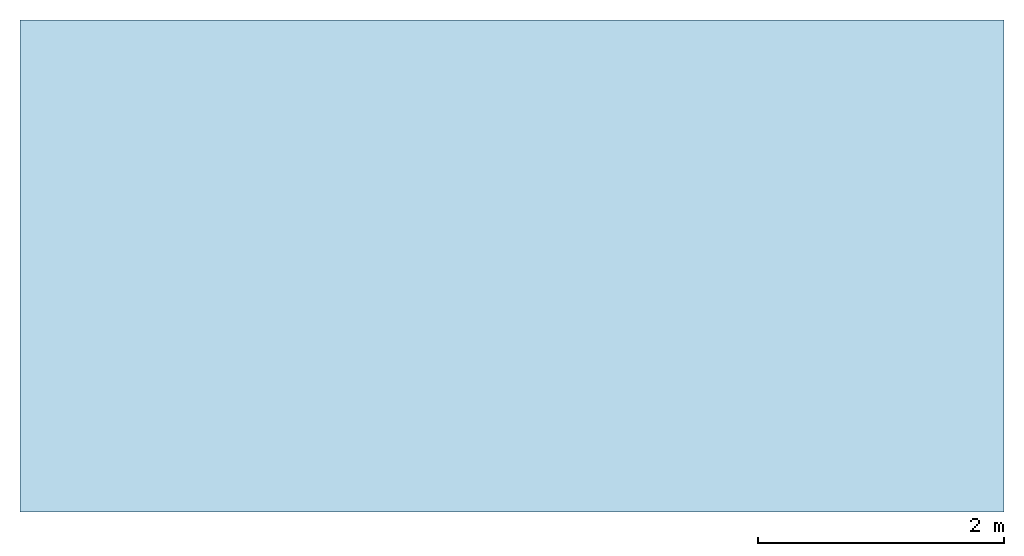
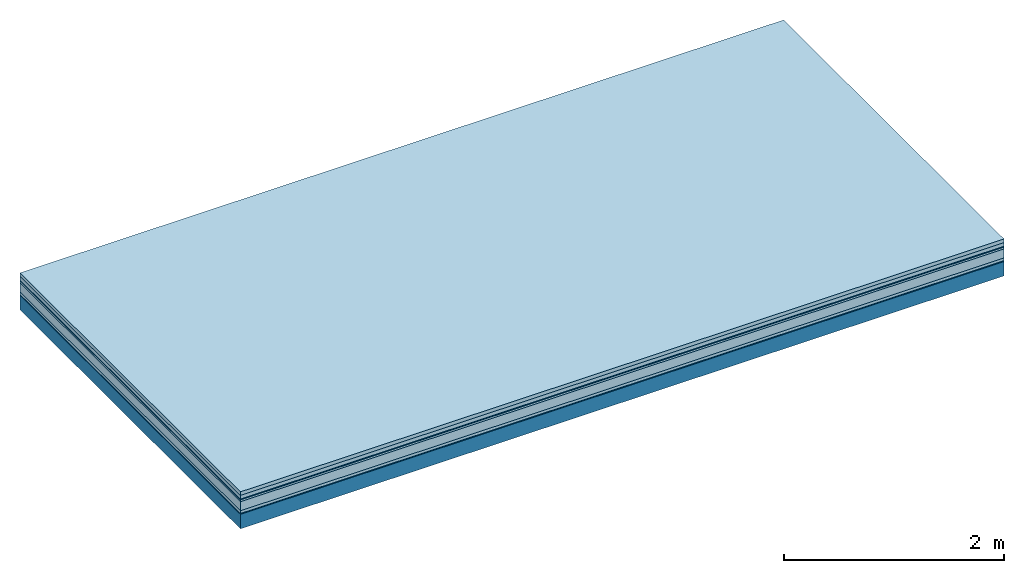
# One storey: 7 plates, 1 member, 1 element without a shape of its own.
"""IFC4 building model written with IfcOpenShell, lengths in metres."""

from ifc_helpers import new_model, si_unit, derived_unit, direction, frame, frame_2d, origin, origin_with_axes, place, context, project, spatial, rectangle, extrude, material, layer, layer_set, type_object, element, aggregate, save


model = new_model("IFC4")

# Units and contexts
plan_context = context("Plan", 3, precision=1e-05, world=origin(), true_north=direction((0.0, 1.0)))
model_context = context("Model", 3, precision=1e-05, world=origin(), true_north=direction((0.0, 1.0)))
ifc_project = project(units=[si_unit("LENGTHUNIT", "METRE"), derived_unit("SOUNDPRESSUREUNIT", [(si_unit("PRESSUREUNIT", "PASCAL", prefix="MICRO"), 0)]), si_unit("ENERGYUNIT", "JOULE", prefix="MEGA"), si_unit("MASSUNIT", "GRAM", prefix="KILO"), derived_unit("THERMALTRANSMITTANCEUNIT", [(si_unit("POWERUNIT", "WATT"), 1), (si_unit("AREAUNIT", "SQUARE_METRE"), -1), (si_unit("THERMODYNAMICTEMPERATUREUNIT", "KELVIN"), -1)]), derived_unit("AREADENSITYUNIT", [(si_unit("MASSUNIT", "GRAM", prefix="KILO"), 1), (si_unit("AREAUNIT", "SQUARE_METRE"), -1)]), derived_unit("USERDEFINED", [(si_unit("ENERGYUNIT", "JOULE", prefix="MEGA"), 1), (si_unit("AREAUNIT", "SQUARE_METRE"), -1)])], contexts=[plan_context, model_context])

# Site, building, storey
site = spatial("IfcSite", under=ifc_project)
building_placement = place(None, origin())
building = spatial("IfcBuilding", under=site, at=building_placement)
storey_placement = place(building_placement, origin())
storey = spatial("IfcBuildingStorey", under=building, at=storey_placement)

# Slab, member, plates
ifc_material_1 = material(Name="Garden plates", Category="02.007")
ifc_layer_1 = layer(ifc_material_1, 0.04, Name="Use and protection layer 3")
ifc_material_2 = material(Name="Gravel 8-16mm", Category="03.011")
ifc_layer_2 = layer(ifc_material_2, 0.04, Name="Use and protection layer 2")
ifc_material_3 = material(Name="Protective layer", Category="09.007")
ifc_layer_3 = layer(ifc_material_3, 0.01, Name="Use and protection layer 1")
ifc_material_4 = material(Name="Bituminous", Category="09.003")
ifc_layer_4 = layer(ifc_material_4, 0.02, Name="Seal")
ifc_material_5 = material(Category="10.006")
ifc_layer_5 = layer(ifc_material_5, 0.1, Name="Exterior insulation layer 2")
ifc_material_6 = material(Name="(034) 25 boards", Category="10.004")
ifc_layer_6 = layer(ifc_material_6, 0.03, Name="Exterior insulation layer 1")
ifc_material_7 = material(Name="Vapor-permeable barrier", Category="09.006")
ifc_layer_7 = layer(ifc_material_7, 0.01, Name="layer / temporary roof")
ifc_material_8 = material(Name="no composite action")
ifc_layer_8 = layer(ifc_material_8, 0.0, Name="Bond")
ifc_layer_9 = layer(None, 0.16, Name="Support")
ifc_layer_set = layer_set([ifc_layer_1, ifc_layer_2, ifc_layer_3, ifc_layer_4, ifc_layer_5, ifc_layer_6, ifc_layer_7, ifc_layer_8, ifc_layer_9])
slab_type = type_object("IfcSlabType", Name="F0059", PredefinedType="NOTDEFINED", material=ifc_layer_set)
slab_placement = place(None, frame((0.0, 0.0, 0.0), z_axis=(0.0, 0.0, -1.0), x_axis=(1.0, 0.0, 0.0)))
slab = element("IfcSlab", 1, at=slab_placement, inside=storey, type_object=slab_type, material=ifc_layer_set, Name="Slab #1")
ifc_material_9 = material(Name="Solid timber panel")
member_placement = place(slab_placement, origin())
member = element("IfcMember", 2, at=member_placement, material=ifc_material_9, Name="Support", context=plan_context, shape_type="SweptSolid", body=[
    extrude(rectangle(XDim=1.0, YDim=0.16, at=frame_2d((0.5, 0.08), x_axis=(1.0, 0.0))), frame((0.0, 4.0, 0.25), z_axis=(0.0, -1.0, 0.0), x_axis=(1.0, 0.0, 0.0)), (0.0, 0.0, 1.0), 4.0),
    extrude(rectangle(XDim=1.0, YDim=0.16, at=frame_2d((0.5, 0.08), x_axis=(1.0, 0.0))), frame((1.0, 4.0, 0.25), z_axis=(0.0, -1.0, 0.0), x_axis=(1.0, 0.0, 0.0)), (0.0, 0.0, 1.0), 4.0),
    extrude(rectangle(XDim=1.0, YDim=0.16, at=frame_2d((0.5, 0.08), x_axis=(1.0, 0.0))), frame((2.0, 4.0, 0.25), z_axis=(0.0, -1.0, 0.0), x_axis=(1.0, 0.0, 0.0)), (0.0, 0.0, 1.0), 4.0),
    extrude(rectangle(XDim=1.0, YDim=0.16, at=frame_2d((0.5, 0.08), x_axis=(1.0, 0.0))), frame((3.0, 4.0, 0.25), z_axis=(0.0, -1.0, 0.0), x_axis=(1.0, 0.0, 0.0)), (0.0, 0.0, 1.0), 4.0),
    extrude(rectangle(XDim=1.0, YDim=0.16, at=frame_2d((0.5, 0.08), x_axis=(1.0, 0.0))), frame((4.0, 4.0, 0.25), z_axis=(0.0, -1.0, 0.0), x_axis=(1.0, 0.0, 0.0)), (0.0, 0.0, 1.0), 4.0),
    extrude(rectangle(XDim=1.0, YDim=0.16, at=frame_2d((0.5, 0.08), x_axis=(1.0, 0.0))), frame((5.0, 4.0, 0.25), z_axis=(0.0, -1.0, 0.0), x_axis=(1.0, 0.0, 0.0)), (0.0, 0.0, 1.0), 4.0),
    extrude(rectangle(XDim=1.0, YDim=0.16, at=frame_2d((0.5, 0.08), x_axis=(1.0, 0.0))), frame((6.0, 4.0, 0.25), z_axis=(0.0, -1.0, 0.0), x_axis=(1.0, 0.0, 0.0)), (0.0, 0.0, 1.0), 4.0),
    extrude(rectangle(XDim=1.0, YDim=0.16, at=frame_2d((0.5, 0.08), x_axis=(1.0, 0.0))), frame((7.0, 4.0, 0.25), z_axis=(0.0, -1.0, 0.0), x_axis=(1.0, 0.0, 0.0)), (0.0, 0.0, 1.0), 4.0),
])
plate_1_placement = place(slab_placement, origin())
plate_1 = element("IfcPlate", 3, at=plate_1_placement, material=ifc_material_1, Name="Use and protection layer 3", context=plan_context, shape_type="SweptSolid", body=[
    extrude(rectangle(XDim=8.0, YDim=4.0, at=frame_2d((4.0, 2.0), x_axis=(1.0, 0.0))), origin_with_axes(), (0.0, 0.0, 1.0), 0.04),
])
plate_2_placement = place(slab_placement, origin())
plate_2 = element("IfcPlate", 4, at=plate_2_placement, material=ifc_material_2, Name="Use and protection layer 2", context=plan_context, shape_type="SweptSolid", body=[
    extrude(rectangle(XDim=8.0, YDim=4.0, at=frame_2d((4.0, 2.0), x_axis=(1.0, 0.0))), frame((0.0, 0.0, 0.04), z_axis=(0.0, 0.0, 1.0), x_axis=(1.0, 0.0, 0.0)), (0.0, 0.0, 1.0), 0.04),
])
plate_3_placement = place(slab_placement, origin())
plate_3 = element("IfcPlate", 5, at=plate_3_placement, material=ifc_material_3, Name="Use and protection layer 1", context=plan_context, shape_type="SweptSolid", body=[
    extrude(rectangle(XDim=8.0, YDim=4.0, at=frame_2d((4.0, 2.0), x_axis=(1.0, 0.0))), frame((0.0, 0.0, 0.08), z_axis=(0.0, 0.0, 1.0), x_axis=(1.0, 0.0, 0.0)), (0.0, 0.0, 1.0), 0.01),
])
plate_4_placement = place(slab_placement, origin())
plate_4 = element("IfcPlate", 6, at=plate_4_placement, material=ifc_material_4, Name="Seal", context=plan_context, shape_type="SweptSolid", body=[
    extrude(rectangle(XDim=8.0, YDim=4.0, at=frame_2d((4.0, 2.0), x_axis=(1.0, 0.0))), frame((0.0, 0.0, 0.09), z_axis=(0.0, 0.0, 1.0), x_axis=(1.0, 0.0, 0.0)), (0.0, 0.0, 1.0), 0.02),
])
plate_5_placement = place(slab_placement, origin())
plate_5 = element("IfcPlate", 7, at=plate_5_placement, material=ifc_material_5, Name="Exterior insulation layer 2", context=plan_context, shape_type="SweptSolid", body=[
    extrude(rectangle(XDim=8.0, YDim=4.0, at=frame_2d((4.0, 2.0), x_axis=(1.0, 0.0))), frame((0.0, 0.0, 0.11), z_axis=(0.0, 0.0, 1.0), x_axis=(1.0, 0.0, 0.0)), (0.0, 0.0, 1.0), 0.1),
])
plate_6_placement = place(slab_placement, origin())
plate_6 = element("IfcPlate", 8, at=plate_6_placement, material=ifc_material_6, Name="Exterior insulation layer 1", context=plan_context, shape_type="SweptSolid", body=[
    extrude(rectangle(XDim=8.0, YDim=4.0, at=frame_2d((4.0, 2.0), x_axis=(1.0, 0.0))), frame((0.0, 0.0, 0.21), z_axis=(0.0, 0.0, 1.0), x_axis=(1.0, 0.0, 0.0)), (0.0, 0.0, 1.0), 0.03),
])
plate_7_placement = place(slab_placement, origin())
plate_7 = element("IfcPlate", 9, at=plate_7_placement, material=ifc_material_7, Name="layer / temporary roof", context=plan_context, shape_type="SweptSolid", body=[
    extrude(rectangle(XDim=8.0, YDim=4.0, at=frame_2d((4.0, 2.0), x_axis=(1.0, 0.0))), frame((0.0, 0.0, 0.24), z_axis=(0.0, 0.0, 1.0), x_axis=(1.0, 0.0, 0.0)), (0.0, 0.0, 1.0), 0.01),
])
aggregate(slab, [plate_1, plate_2, plate_3, plate_4, plate_5, plate_6, plate_7, member])

save(model, "model.ifc")
